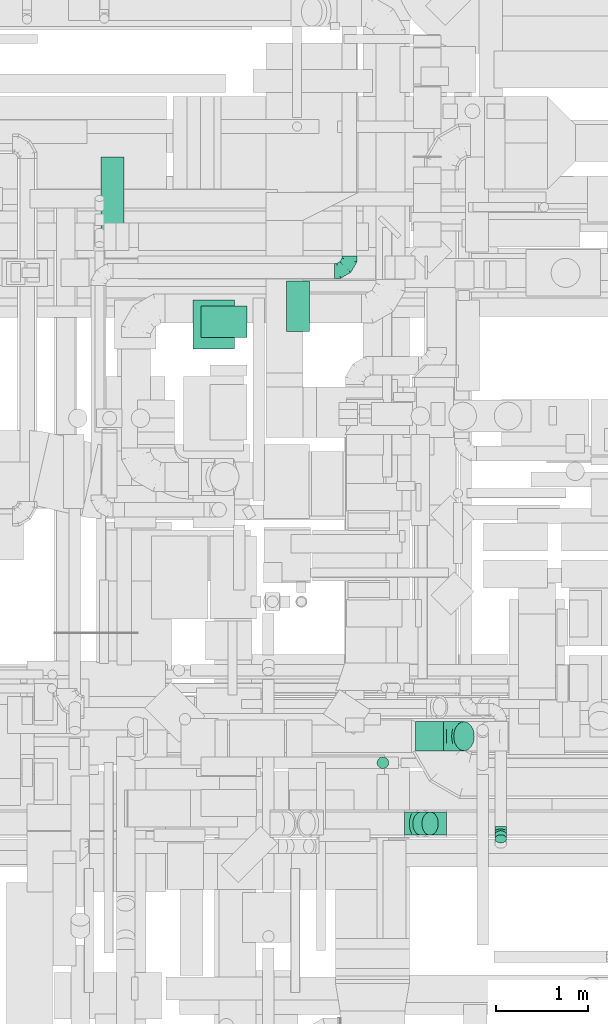
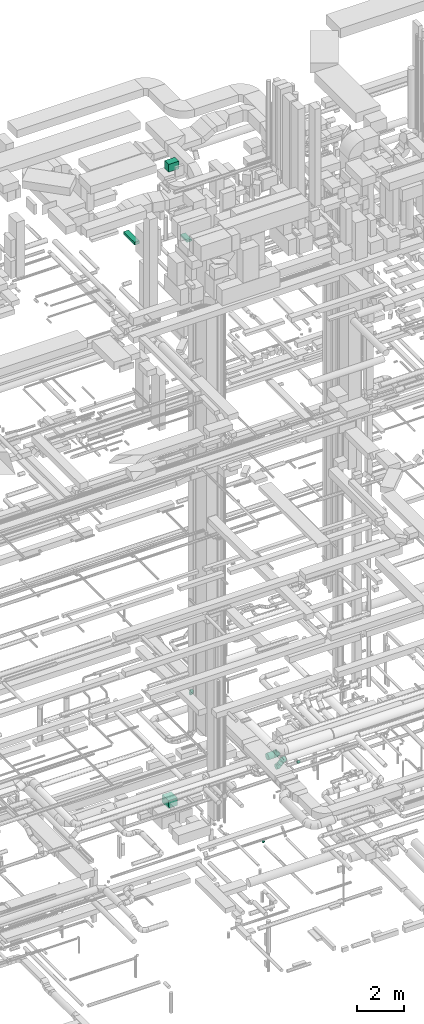
# One storey, part 178 of 337: 8 flow segments, 5 flow fittings.
"""IFC2X3 building model written with IfcOpenShell, lengths in millimetres."""

from ifc_helpers import new_model, entity, si_unit, converted_unit, derived_unit, direction, frame, origin, origin_2d_with_axis, place, context, subcontext, project, spatial, rectangle, circle, extrude, faceted_brep, source, transform, mapped, material, type_object, type_shapes, element, save


model = new_model("IFC2X3")

# Units and contexts
model_context = context("Model", 3, precision=0.01, world=origin(), true_north=direction((6.12303176911189e-17, 1.0)))
body_context = subcontext(model_context, "Body", "Model", "MODEL_VIEW")
ifc_project = project(units=[si_unit("LENGTHUNIT", "METRE", prefix="MILLI"), si_unit("AREAUNIT", "SQUARE_METRE"), si_unit("VOLUMEUNIT", "CUBIC_METRE"), converted_unit("PLANEANGLEUNIT", "DEGREE", entity("IfcRatioMeasure", 0.0174532925199433), si_unit("PLANEANGLEUNIT", "RADIAN"), dimensions=[0, 0, 0, 0, 0, 0, 0]), si_unit("MASSUNIT", "GRAM", prefix="KILO"), derived_unit("MASSDENSITYUNIT", [(si_unit("MASSUNIT", "GRAM", prefix="KILO"), 1), (si_unit("LENGTHUNIT", "METRE"), -3)]), derived_unit("MOMENTOFINERTIAUNIT", [(si_unit("LENGTHUNIT", "METRE"), 4)]), si_unit("TIMEUNIT", "SECOND"), si_unit("FREQUENCYUNIT", "HERTZ"), si_unit("THERMODYNAMICTEMPERATUREUNIT", "DEGREE_CELSIUS"), derived_unit("THERMALTRANSMITTANCEUNIT", [(si_unit("MASSUNIT", "GRAM", prefix="KILO"), 1), (si_unit("THERMODYNAMICTEMPERATUREUNIT", "KELVIN"), -1), (si_unit("TIMEUNIT", "SECOND"), -3)]), derived_unit("VOLUMETRICFLOWRATEUNIT", [(si_unit("LENGTHUNIT", "METRE"), 3), (si_unit("TIMEUNIT", "SECOND"), -1)]), derived_unit("MASSFLOWRATEUNIT", [(si_unit("MASSUNIT", "GRAM", prefix="KILO"), 1), (si_unit("TIMEUNIT", "SECOND"), -1)]), derived_unit("ROTATIONALFREQUENCYUNIT", [(si_unit("TIMEUNIT", "SECOND"), -1)]), si_unit("ELECTRICCURRENTUNIT", "AMPERE"), si_unit("ELECTRICVOLTAGEUNIT", "VOLT"), si_unit("POWERUNIT", "WATT"), si_unit("FORCEUNIT", "NEWTON", prefix="KILO"), si_unit("ILLUMINANCEUNIT", "LUX"), si_unit("LUMINOUSFLUXUNIT", "LUMEN"), si_unit("LUMINOUSINTENSITYUNIT", "CANDELA"), derived_unit("USERDEFINED", [(si_unit("MASSUNIT", "GRAM", prefix="KILO"), -1), (si_unit("LENGTHUNIT", "METRE"), -2), (si_unit("TIMEUNIT", "SECOND"), 3), (si_unit("LUMINOUSFLUXUNIT", "LUMEN"), 1)]), derived_unit("LINEARVELOCITYUNIT", [(si_unit("LENGTHUNIT", "METRE"), 1), (si_unit("TIMEUNIT", "SECOND"), -1)]), si_unit("PRESSUREUNIT", "PASCAL"), derived_unit("USERDEFINED", [(si_unit("LENGTHUNIT", "METRE"), -2), (si_unit("MASSUNIT", "GRAM", prefix="KILO"), 1), (si_unit("TIMEUNIT", "SECOND"), -2)]), derived_unit("LINEARFORCEUNIT", [(si_unit("MASSUNIT", "GRAM", prefix="KILO"), 1), (si_unit("LENGTHUNIT", "METRE"), 1), (si_unit("TIMEUNIT", "SECOND"), -2), (si_unit("LENGTHUNIT", "METRE"), -1)]), derived_unit("PLANARFORCEUNIT", [(si_unit("MASSUNIT", "GRAM", prefix="KILO"), 1), (si_unit("LENGTHUNIT", "METRE"), 1), (si_unit("TIMEUNIT", "SECOND"), -2), (si_unit("LENGTHUNIT", "METRE"), -2)])], contexts=[model_context])

# Site, building, storey
site_placement = place(None, origin())
site = spatial("IfcSite", under=ifc_project, at=site_placement, CompositionType="ELEMENT")
building_placement = place(site_placement, origin())
building = spatial("IfcBuilding", under=site, at=building_placement, CompositionType="ELEMENT")
storey_placement = place(building_placement, origin())
storey = spatial("IfcBuildingStorey", under=building, at=storey_placement, CompositionType="ELEMENT", Elevation=0.0)

# Flow segments
duct_segment_type_1 = type_object("IfcDuctSegmentType", PredefinedType="NOTDEFINED")
flow_segment_1_placement = place(storey_placement, frame((44232.27, 13725.33, -1300.0)))
element("IfcFlowSegment", 1, at=flow_segment_1_placement, inside=storey, type_object=duct_segment_type_1, context=body_context, shape_type="SweptSolid", body=[
    extrude(rectangle(XDim=528.06163199991, YDim=450.000000000002, at=origin_2d_with_axis()), frame((225.0, 264.03, 0.0), z_axis=(0.0, 0.0, 1.0), x_axis=(0.0, 1.0, 0.0)), (0.0, 0.0, 1.0), 400.0),
])
flow_segment_2_placement = place(storey_placement, frame((43238.94, 14881.21, 27475.0)))
element("IfcFlowSegment", 2, at=flow_segment_2_placement, inside=storey, type_object=duct_segment_type_1, context=body_context, shape_type="SweptSolid", body=[
    extrude(rectangle(XDim=919.338745030391, YDim=250.000000000004, at=origin_2d_with_axis()), frame((125.0, 459.67, 0.0), z_axis=(0.0, 0.0, 1.0), x_axis=(0.0, 1.0, 0.0)), (0.0, 0.0, 1.0), 150.000000000001),
])
flow_segment_3_placement = place(storey_placement, frame((45243.22, 13913.71, 27500.0)))
element("IfcFlowSegment", 3, at=flow_segment_3_placement, inside=storey, type_object=duct_segment_type_1, context=body_context, shape_type="SweptSolid", body=[
    extrude(rectangle(XDim=547.499999999984, YDim=250.000000000004, at=origin_2d_with_axis()), frame((125.0, 273.75, 0.0), z_axis=(0.0, 0.0, 1.0), x_axis=(0.0, -1.0, 0.0)), (0.0, 0.0, 1.0), 100.000000000003),
])
flow_segment_4_placement = place(storey_placement, frame((44320.31, 13849.12, 31500.0)))
element("IfcFlowSegment", 4, at=flow_segment_4_placement, inside=storey, type_object=duct_segment_type_1, context=body_context, shape_type="SweptSolid", body=[
    extrude(rectangle(XDim=340.000000000118, YDim=499.999999999999, at=origin_2d_with_axis()), frame((250.0, 170.0, 0.0), z_axis=(0.0, 0.0, 1.0), x_axis=(0.0, -1.0, 0.0)), (0.0, 0.0, 1.0), 399.999999999996),
])
duct_segment_type_2 = type_object("IfcDuctSegmentType", PredefinedType="NOTDEFINED")
flow_segment_5_placement = place(storey_placement, frame((46225.29, 9180.91, -1035.0)))
element("IfcFlowSegment", 5, at=flow_segment_5_placement, inside=storey, type_object=duct_segment_type_2, context=body_context, shape_type="SweptSolid", body=[
    extrude(circle(Radius=62.5, at=origin_2d_with_axis()), frame((64.1, 64.1, 0.0), z_axis=(0.0, 1.27955975282367e-05, 1.0), x_axis=(0.0, -1.0, 1.27955975282367e-05)), (0.0, 0.0, 1.0), 52.503404808983),
])
flow_segment_6_placement = place(storey_placement, frame((46611.51, 8460.07, 3163.24)))
element("IfcFlowSegment", 6, at=flow_segment_6_placement, inside=storey, type_object=duct_segment_type_2, context=body_context, shape_type="SweptSolid", body=[
    extrude(circle(Radius=125.0, at=origin_2d_with_axis()), frame((89.98, 126.6, 89.98), z_axis=(0.707106781186548, 0.0, 0.707106781186548), x_axis=(0.0, -1.0, 0.0)), (0.0, 0.0, 1.0), 139.375541594848),
])
flow_segment_7_placement = place(storey_placement, frame((47500.5, 8376.54, 3090.82)))
element("IfcFlowSegment", 7, at=flow_segment_7_placement, inside=storey, type_object=duct_segment_type_2, context=body_context, shape_type="SweptSolid", body=[
    extrude(circle(Radius=62.5, at=origin_2d_with_axis()), frame((64.1, 45.79, 89.36), z_axis=(0.0, 0.707106781186485, -0.70710678118661), x_axis=(-1.0, 0.0, 0.0)), (0.0, 0.0, 1.0), 61.6152603191933),
])
flow_segment_8_placement = place(storey_placement, frame((46641.56, 9373.4, 2920.9)))
element("IfcFlowSegment", 8, at=flow_segment_8_placement, inside=storey, type_object=duct_segment_type_2, context=body_context, shape_type="SweptSolid", body=[
    extrude(circle(Radius=157.5, at=origin_2d_with_axis()), frame((0.0, 159.1, 159.1), z_axis=(1.0, 0.0, 0.0), x_axis=(0.0, -1.0, 0.0)), (0.0, 0.0, 1.0), 302.74255936727),
])

# Flow fittings
ifc_material = material()
duct_fitting_type_1 = type_object("IfcDuctFittingType", PredefinedType="NOTDEFINED", material=ifc_material)
shared_shape_1 = source(origin(), body_context, "Body", "Brep", [
    faceted_brep([(-160.0, 0.0, -80.0), (-160.0, -20.71, -77.27), (-160.0, -40.0, -69.28), (-160.0, -56.57, -56.57), (-160.0, -69.28, -40.0), (-160.0, -77.27, -20.71), (-160.0, -80.0, 0.0), (-160.0, -77.27, 20.71), (-160.0, -69.28, 40.0), (-160.0, -56.57, 56.57), (-160.0, -40.0, 69.28), (-160.0, -20.71, 77.27), (-160.0, 0.0, 80.0), (-160.0, 20.71, 77.27), (-160.0, 40.0, 69.28), (-160.0, 56.57, 56.57), (-160.0, 69.28, 40.0), (-160.0, 77.27, 20.71), (-160.0, 80.0, 0.0), (-160.0, 77.27, -20.71), (-160.0, 69.28, -40.0), (-160.0, 56.57, -56.57), (-160.0, 40.0, -69.28), (-160.0, 20.71, -77.27), (-122.68, 20.71, 77.27), (-127.85, 40.0, 69.28), (-117.13, 0.0, 80.0), (-132.29, 56.57, 56.57), (-137.83, 77.27, 20.71), (-138.56, 80.0, 0.0), (-135.69, 69.28, 40.0), (-135.69, 69.28, -40.0), (-132.29, 56.57, -56.57), (-137.83, 77.27, -20.71), (-122.68, 20.71, -77.27), (-117.13, 0.0, -80.0), (-127.85, 40.0, -69.28), (-111.58, -20.71, -77.27), (-106.41, -40.0, -69.28), (-101.97, -56.57, -56.57), (-98.56, -69.28, -40.0), (-96.42, -77.27, -20.71), (-95.69, -80.0, 0.0), (-96.42, -77.27, 20.71), (-98.56, -69.28, 40.0), (-101.97, -56.57, 56.57), (-106.41, -40.0, 69.28), (-111.58, -20.71, 77.27), (-58.03, 58.03, 77.27), (-72.15, 72.15, 69.28), (-42.87, 42.87, 80.0), (-84.28, 84.28, 56.57), (-93.59, 93.59, 40.0), (-99.44, 99.44, 20.71), (-101.44, 101.44, 0.0), (-99.44, 99.44, -20.71), (-93.59, 93.59, -40.0), (-84.28, 84.28, -56.57), (-58.03, 58.03, -77.27), (-42.87, 42.87, -80.0), (-72.15, 72.15, -69.28), (-27.71, 27.71, -77.27), (-13.59, 13.59, -69.28), (-1.46, 1.46, -56.57), (7.85, -7.85, -40.0), (13.7, -13.7, -20.71), (15.69, -15.69, 0.0), (13.7, -13.7, 20.71), (7.85, -7.85, 40.0), (-1.46, 1.46, 56.57), (-13.59, 13.59, 69.28), (-27.71, 27.71, 77.27), (-20.71, 122.68, 77.27), (-40.0, 127.85, 69.28), (0.0, 117.13, 80.0), (-56.57, 132.29, 56.57), (-69.28, 135.69, 40.0), (-77.27, 137.83, 20.71), (-80.0, 138.56, 0.0), (-77.27, 137.83, -20.71), (-69.28, 135.69, -40.0), (-56.57, 132.29, -56.57), (-20.71, 122.68, -77.27), (0.0, 117.13, -80.0), (-40.0, 127.85, -69.28), (20.71, 111.58, -77.27), (40.0, 106.41, -69.28), (56.57, 101.97, -56.57), (69.28, 98.56, -40.0), (77.27, 96.42, -20.71), (80.0, 95.69, 0.0), (77.27, 96.42, 20.71), (69.28, 98.56, 40.0), (56.57, 101.97, 56.57), (40.0, 106.41, 69.28), (20.71, 111.58, 77.27), (-20.71, 160.0, -77.27), (-40.0, 160.0, -69.28), (-56.57, 160.0, -56.57), (-69.28, 160.0, -40.0), (-77.27, 160.0, -20.71), (-80.0, 160.0, 0.0), (-77.27, 160.0, 20.71), (-69.28, 160.0, 40.0), (-56.57, 160.0, 56.57), (-40.0, 160.0, 69.28), (-20.71, 160.0, 77.27), (0.0, 160.0, 80.0), (20.71, 160.0, 77.27), (40.0, 160.0, 69.28), (56.57, 160.0, 56.57), (69.28, 160.0, 40.0), (77.27, 160.0, 20.71), (80.0, 160.0, 0.0), (77.27, 160.0, -20.71), (69.28, 160.0, -40.0), (56.57, 160.0, -56.57), (40.0, 160.0, -69.28), (20.71, 160.0, -77.27), (0.0, 160.0, -80.0)], [[[0, 1, 2, 3, 4, 5, 6, 7, 8, 9, 10, 11, 12, 13, 14, 15, 16, 17, 18, 19, 20, 21, 22, 23]], [[24, 25, 14, 13]], [[26, 24, 13, 12]], [[14, 25, 27, 15]], [[28, 29, 18, 17]], [[30, 28, 17, 16]], [[15, 27, 30, 16]], [[20, 31, 32, 21]], [[33, 31, 20, 19]], [[18, 29, 33, 19]], [[34, 35, 0, 23]], [[36, 34, 23, 22]], [[32, 36, 22, 21]], [[1, 0, 35, 37]], [[2, 1, 37, 38]], [[3, 2, 38, 39]], [[5, 4, 40, 41]], [[6, 5, 41, 42]], [[39, 40, 4, 3]], [[6, 42, 43, 7]], [[7, 43, 44, 8]], [[8, 44, 45, 9]], [[9, 45, 46, 10]], [[10, 46, 47, 11]], [[26, 12, 11, 47]], [[48, 49, 25, 24]], [[50, 48, 24, 26]], [[27, 25, 49, 51]], [[52, 53, 28, 30]], [[51, 52, 30, 27]], [[29, 28, 53, 54]], [[55, 56, 31, 33]], [[54, 55, 33, 29]], [[32, 31, 56, 57]], [[58, 59, 35, 34]], [[60, 58, 34, 36]], [[57, 60, 36, 32]], [[37, 35, 59, 61]], [[38, 37, 61, 62]], [[39, 38, 62, 63]], [[41, 40, 64, 65]], [[42, 41, 65, 66]], [[63, 64, 40, 39]], [[43, 42, 66, 67]], [[44, 43, 67, 68]], [[68, 69, 45, 44]], [[46, 45, 69, 70]], [[47, 46, 70, 71]], [[26, 47, 71, 50]], [[72, 73, 49, 48]], [[74, 72, 48, 50]], [[51, 49, 73, 75]], [[76, 77, 53, 52]], [[75, 76, 52, 51]], [[54, 53, 77, 78]], [[79, 80, 56, 55]], [[78, 79, 55, 54]], [[57, 56, 80, 81]], [[82, 83, 59, 58]], [[84, 82, 58, 60]], [[81, 84, 60, 57]], [[61, 59, 83, 85]], [[62, 61, 85, 86]], [[63, 62, 86, 87]], [[65, 64, 88, 89]], [[66, 65, 89, 90]], [[87, 88, 64, 63]], [[67, 66, 90, 91]], [[68, 67, 91, 92]], [[92, 93, 69, 68]], [[70, 69, 93, 94]], [[71, 70, 94, 95]], [[50, 71, 95, 74]], [[96, 97, 98, 99, 100, 101, 102, 103, 104, 105, 106, 107, 108, 109, 110, 111, 112, 113, 114, 115, 116, 117, 118, 119]], [[72, 74, 107, 106]], [[73, 72, 106, 105]], [[75, 73, 105, 104]], [[77, 76, 103, 102]], [[78, 77, 102, 101]], [[75, 104, 103, 76]], [[78, 101, 100, 79]], [[79, 100, 99, 80]], [[80, 99, 98, 81]], [[84, 97, 96, 82]], [[82, 96, 119, 83]], [[84, 81, 98, 97]], [[118, 117, 86, 85]], [[119, 118, 85, 83]], [[116, 87, 86, 117]], [[88, 115, 114, 89]], [[89, 114, 113, 90]], [[115, 88, 87, 116]], [[112, 111, 92, 91]], [[113, 112, 91, 90]], [[111, 110, 93, 92]], [[95, 94, 109, 108]], [[74, 95, 108, 107]], [[110, 109, 94, 93]]]),
])
type_shapes(duct_fitting_type_1, [shared_shape_1])
flow_fitting_1_placement = place(storey_placement, frame((45926.64, 14568.87, 3600.0)))
element("IfcFlowFitting", 9, at=flow_fitting_1_placement, inside=storey, type_object=duct_fitting_type_1, material=ifc_material, context=body_context, shape_type="MappedRepresentation", body=[
    mapped(shared_shape_1, transform((0.0, 0.0, 0.0), scale=1.0)),
])
duct_fitting_type_2 = type_object("IfcDuctFittingType", PredefinedType="NOTDEFINED", material=ifc_material)
shared_shape_2 = source(origin(), body_context, "Body", "Brep", [
    faceted_brep([(-51.78, 0.0, -62.5), (-51.78, -16.18, -60.37), (-51.78, -31.25, -54.13), (-51.78, -44.19, -44.19), (-51.78, -54.13, -31.25), (-51.78, -60.37, -16.18), (-51.78, -62.5, 0.0), (-51.78, -60.37, 16.18), (-51.78, -54.13, 31.25), (-51.78, -44.19, 44.19), (-51.78, -31.25, 54.13), (-51.78, -16.18, 60.37), (-51.78, 0.0, 62.5), (-51.78, 16.18, 60.37), (-51.78, 31.25, 54.13), (-51.78, 44.19, 44.19), (-51.78, 54.13, 31.25), (-51.78, 60.37, 16.18), (-51.78, 62.5, 0.0), (-51.78, 60.37, -16.18), (-51.78, 54.13, -31.25), (-51.78, 44.19, -44.19), (-51.78, 31.25, -54.13), (-51.78, 16.18, -60.37), (-6.7, 16.18, 60.37), (-12.94, 31.25, 54.13), (0.0, 0.0, 62.5), (-18.31, 44.19, 44.19), (-22.42, 54.13, 31.25), (-25.01, 60.37, 16.18), (-25.89, 62.5, 0.0), (-25.01, 60.37, -16.18), (-22.42, 54.13, -31.25), (-18.31, 44.19, -44.19), (-6.7, 16.18, -60.37), (0.0, 0.0, -62.5), (-12.94, 31.25, -54.13), (6.7, -16.18, -60.37), (12.94, -31.25, -54.13), (18.31, -44.19, -44.19), (22.42, -54.13, -31.25), (25.01, -60.37, -16.18), (25.89, -62.5, 0.0), (25.01, -60.37, 16.18), (22.42, -54.13, 31.25), (18.31, -44.19, 44.19), (12.94, -31.25, 54.13), (6.7, -16.18, 60.37), (25.17, 48.05, 60.37), (14.51, 58.71, 54.13), (36.61, 36.61, 62.5), (5.36, 67.86, 44.19), (-1.66, 74.88, 31.25), (-6.08, 79.3, 16.18), (-7.58, 80.81, 0.0), (-6.08, 79.3, -16.18), (-1.66, 74.88, -31.25), (5.36, 67.86, -44.19), (14.51, 58.71, -54.13), (25.17, 48.05, -60.37), (36.61, 36.61, -62.5), (48.05, 25.17, -60.37), (58.71, 14.51, -54.13), (67.86, 5.36, -44.19), (74.88, -1.66, -31.25), (79.3, -6.08, -16.18), (80.81, -7.58, 0.0), (79.3, -6.08, 16.18), (74.88, -1.66, 31.25), (67.86, 5.36, 44.19), (58.71, 14.51, 54.13), (48.05, 25.17, 60.37)], [[[0, 1, 2, 3, 4, 5, 6, 7, 8, 9, 10, 11, 12, 13, 14, 15, 16, 17, 18, 19, 20, 21, 22, 23]], [[24, 25, 14, 13]], [[26, 24, 13, 12]], [[27, 15, 14, 25]], [[28, 29, 17, 16]], [[28, 16, 15, 27]], [[30, 18, 17, 29]], [[31, 32, 20, 19]], [[30, 31, 19, 18]], [[21, 20, 32, 33]], [[34, 35, 0, 23]], [[36, 34, 23, 22]], [[33, 36, 22, 21]], [[1, 0, 35, 37]], [[2, 1, 37, 38]], [[38, 39, 3, 2]], [[5, 4, 40, 41]], [[6, 5, 41, 42]], [[39, 40, 4, 3]], [[6, 42, 43, 7]], [[7, 43, 44, 8]], [[8, 44, 45, 9]], [[9, 45, 46, 10]], [[10, 46, 47, 11]], [[26, 12, 11, 47]], [[48, 49, 25, 24]], [[50, 48, 24, 26]], [[27, 25, 49, 51]], [[29, 28, 52, 53]], [[30, 29, 53, 54]], [[51, 52, 28, 27]], [[30, 54, 55, 31]], [[31, 55, 56, 32]], [[57, 33, 32, 56]], [[36, 58, 59, 34]], [[34, 59, 60, 35]], [[58, 36, 33, 57]], [[35, 60, 61, 37]], [[37, 61, 62, 38]], [[63, 39, 38, 62]], [[40, 64, 65, 41]], [[41, 65, 66, 42]], [[64, 40, 39, 63]], [[43, 42, 66, 67]], [[44, 43, 67, 68]], [[68, 69, 45, 44]], [[47, 46, 70, 71]], [[26, 47, 71, 50]], [[69, 70, 46, 45]], [[59, 58, 57, 56, 55, 54, 53, 52, 51, 49, 48, 50, 71, 70, 69, 68, 67, 66, 65, 64, 63, 62, 61, 60]]]),
])
type_shapes(duct_fitting_type_2, [shared_shape_2])
flow_fitting_2_placement = place(storey_placement, frame((47564.59, 8502.51, 3100.0), z_axis=(-1.0, 0.0, 0.0), x_axis=(0.0, -1.0, 0.0)))
element("IfcFlowFitting", 10, at=flow_fitting_2_placement, inside=storey, type_object=duct_fitting_type_2, material=ifc_material, context=body_context, shape_type="MappedRepresentation", body=[
    mapped(shared_shape_2, transform((0.0, 0.0, 0.0), scale=1.0)),
])
duct_fitting_type_3 = type_object("IfcDuctFittingType", PredefinedType="NOTDEFINED", material=ifc_material)
shared_shape_3 = source(origin(), body_context, "Body", "Brep", [
    faceted_brep([(-103.55, 0.0, -125.0), (-103.55, -32.35, -120.74), (-103.55, -62.5, -108.25), (-103.55, -88.39, -88.39), (-103.55, -108.25, -62.5), (-103.55, -120.74, -32.35), (-103.55, -125.0, 0.0), (-103.55, -120.74, 32.35), (-103.55, -108.25, 62.5), (-103.55, -88.39, 88.39), (-103.55, -62.5, 108.25), (-103.55, -32.35, 120.74), (-103.55, 0.0, 125.0), (-103.55, 32.35, 120.74), (-103.55, 62.5, 108.25), (-103.55, 88.39, 88.39), (-103.55, 108.25, 62.5), (-103.55, 120.74, 32.35), (-103.55, 125.0, 0.0), (-103.55, 120.74, -32.35), (-103.55, 108.25, -62.5), (-103.55, 88.39, -88.39), (-103.55, 62.5, -108.25), (-103.55, 32.35, -120.74), (-13.4, 32.35, 120.74), (-25.89, 62.5, 108.25), (0.0, 0.0, 125.0), (-36.61, 88.39, 88.39), (-44.84, 108.25, 62.5), (-50.01, 120.74, 32.35), (-51.78, 125.0, 0.0), (-50.01, 120.74, -32.35), (-44.84, 108.25, -62.5), (-36.61, 88.39, -88.39), (-13.4, 32.35, -120.74), (0.0, 0.0, -125.0), (-25.89, 62.5, -108.25), (13.4, -32.35, -120.74), (25.89, -62.5, -108.25), (36.61, -88.39, -88.39), (44.84, -108.25, -62.5), (50.01, -120.74, -32.35), (51.78, -125.0, 0.0), (50.01, -120.74, 32.35), (44.84, -108.25, 62.5), (36.61, -88.39, 88.39), (25.89, -62.5, 108.25), (13.4, -32.35, 120.74), (73.22, 73.22, 125.0), (50.35, 96.1, 120.74), (29.03, 117.42, 108.25), (10.72, 135.72, 88.39), (-3.32, 149.77, 62.5), (-12.15, 158.6, 32.35), (-15.17, 161.61, 0.0), (-12.15, 158.6, -32.35), (-3.32, 149.77, -62.5), (10.72, 135.72, -88.39), (29.03, 117.42, -108.25), (50.35, 96.1, -120.74), (73.22, 73.22, -125.0), (96.1, 50.35, -120.74), (117.42, 29.03, -108.25), (135.72, 10.72, -88.39), (149.77, -3.32, -62.5), (158.6, -12.15, -32.35), (161.61, -15.17, 0.0), (158.6, -12.15, 32.35), (149.77, -3.32, 62.5), (135.72, 10.72, 88.39), (117.42, 29.03, 108.25), (96.1, 50.35, 120.74)], [[[0, 1, 2, 3, 4, 5, 6, 7, 8, 9, 10, 11, 12, 13, 14, 15, 16, 17, 18, 19, 20, 21, 22, 23]], [[24, 25, 14, 13]], [[26, 24, 13, 12]], [[14, 25, 27, 15]], [[28, 29, 17, 16]], [[28, 16, 15, 27]], [[30, 18, 17, 29]], [[31, 32, 20, 19]], [[30, 31, 19, 18]], [[32, 33, 21, 20]], [[34, 35, 0, 23]], [[36, 34, 23, 22]], [[33, 36, 22, 21]], [[1, 0, 35, 37]], [[2, 1, 37, 38]], [[38, 39, 3, 2]], [[5, 4, 40, 41]], [[6, 5, 41, 42]], [[39, 40, 4, 3]], [[6, 42, 43, 7]], [[7, 43, 44, 8]], [[8, 44, 45, 9]], [[9, 45, 46, 10]], [[10, 46, 47, 11]], [[26, 12, 11, 47]], [[24, 26, 48, 49]], [[25, 24, 49, 50]], [[27, 25, 50, 51]], [[29, 28, 52, 53]], [[30, 29, 53, 54]], [[51, 52, 28, 27]], [[30, 54, 55, 31]], [[31, 55, 56, 32]], [[57, 33, 32, 56]], [[36, 58, 59, 34]], [[34, 59, 60, 35]], [[58, 36, 33, 57]], [[35, 60, 61, 37]], [[37, 61, 62, 38]], [[63, 39, 38, 62]], [[40, 64, 65, 41]], [[41, 65, 66, 42]], [[64, 40, 39, 63]], [[43, 42, 66, 67]], [[44, 43, 67, 68]], [[68, 69, 45, 44]], [[47, 46, 70, 71]], [[26, 47, 71, 48]], [[69, 70, 46, 45]], [[59, 58, 57, 56, 55, 54, 53, 52, 51, 50, 49, 48, 71, 70, 69, 68, 67, 66, 65, 64, 63, 62, 61, 60]]]),
])
type_shapes(duct_fitting_type_3, [shared_shape_3])
for number, where, z_axis, x_axis in (
    (11, (46628.27, 8586.67, 3180.0), (0.0, -1.0, 0.0), (1.0, 0.0, 0.0)),
    (12, (46873.27, 8586.67, 3425.0), (0.0, 1.0, 0.0), (0.707106781186499, 0.0, 0.707106781186596)),
):
    element("IfcFlowFitting", number, at=place(storey_placement, frame(where, z_axis=z_axis, x_axis=x_axis)), inside=storey, type_object=duct_fitting_type_3, material=ifc_material, context=body_context, shape_type="MappedRepresentation", body=[
        mapped(shared_shape_3, transform((0.0, 0.0, 0.0), scale=1.0)),
    ])
duct_fitting_type_4 = type_object("IfcDuctFittingType", PredefinedType="NOTDEFINED", material=ifc_material)
shared_shape_4 = source(origin(), body_context, "Body", "Brep", [
    faceted_brep([(-130.48, 0.0, -157.5), (-130.48, -40.76, -152.13), (-130.48, -78.75, -136.4), (-130.48, -111.37, -111.37), (-130.48, -136.4, -78.75), (-130.48, -152.13, -40.76), (-130.48, -157.5, 0.0), (-130.48, -152.13, 40.76), (-130.48, -136.4, 78.75), (-130.48, -111.37, 111.37), (-130.48, -78.75, 136.4), (-130.48, -40.76, 152.13), (-130.48, 0.0, 157.5), (-130.48, 40.76, 152.13), (-130.48, 78.75, 136.4), (-130.48, 111.37, 111.37), (-130.48, 136.4, 78.75), (-130.48, 152.13, 40.76), (-130.48, 157.5, 0.0), (-130.48, 152.13, -40.76), (-130.48, 136.4, -78.75), (-130.48, 111.37, -111.37), (-130.48, 78.75, -136.4), (-130.48, 40.76, -152.13), (-75.93, 40.76, 152.13), (-83.48, 78.75, 136.4), (-67.82, 0.0, 157.5), (-89.97, 111.37, 111.37), (-94.95, 136.4, 78.75), (-98.08, 152.13, 40.76), (-99.15, 157.5, 0.0), (-98.08, 152.13, -40.76), (-94.95, 136.4, -78.75), (-89.97, 111.37, -111.37), (-75.93, 40.76, -152.13), (-67.82, 0.0, -157.5), (-83.48, 78.75, -136.4), (-59.71, -40.76, -152.13), (-52.16, -78.75, -136.4), (-45.67, -111.37, -111.37), (-40.69, -136.4, -78.75), (-37.56, -152.13, -40.76), (-36.49, -157.5, 0.0), (-37.56, -152.13, 40.76), (-40.69, -136.4, 78.75), (-45.67, -111.37, 111.37), (-52.16, -78.75, 136.4), (-59.71, -40.76, 152.13), (24.86, 82.51, 152.13), (3.35, 114.72, 136.4), (47.96, 47.96, 157.5), (-15.13, 142.37, 111.37), (-29.31, 163.59, 78.75), (-38.22, 176.93, 40.76), (-41.26, 181.48, 0.0), (-38.22, 176.93, -40.76), (-29.31, 163.59, -78.75), (-15.13, 142.37, -111.37), (24.86, 82.51, -152.13), (47.96, 47.96, -157.5), (3.35, 114.72, -136.4), (71.05, 13.4, -152.13), (92.56, -18.81, -136.4), (111.04, -46.46, -111.37), (125.22, -67.68, -78.75), (134.13, -81.02, -40.76), (137.17, -85.57, 0.0), (134.13, -81.02, 40.76), (125.22, -67.68, 78.75), (111.04, -46.46, 111.37), (92.56, -18.81, 136.4), (71.05, 13.4, 152.13), (92.26, 92.26, 157.5), (63.44, 121.09, 152.13), (36.58, 147.95, 136.4), (13.51, 171.01, 111.37), (-4.19, 188.71, 78.75), (-15.31, 199.84, 40.76), (-19.11, 203.63, 0.0), (-15.31, 199.84, -40.76), (-4.19, 188.71, -78.75), (13.51, 171.01, -111.37), (36.58, 147.95, -136.4), (63.44, 121.09, -152.13), (92.26, 92.26, -157.5), (121.09, 63.44, -152.13), (147.95, 36.58, -136.4), (171.01, 13.51, -111.37), (188.71, -4.19, -78.75), (199.84, -15.31, -40.76), (203.63, -19.11, 0.0), (199.84, -15.31, 40.76), (188.71, -4.19, 78.75), (171.01, 13.51, 111.37), (147.95, 36.58, 136.4), (121.09, 63.44, 152.13)], [[[0, 1, 2, 3, 4, 5, 6, 7, 8, 9, 10, 11, 12, 13, 14, 15, 16, 17, 18, 19, 20, 21, 22, 23]], [[24, 25, 14, 13]], [[26, 24, 13, 12]], [[27, 15, 14, 25]], [[28, 29, 17, 16]], [[28, 16, 15, 27]], [[30, 18, 17, 29]], [[31, 32, 20, 19]], [[30, 31, 19, 18]], [[21, 20, 32, 33]], [[34, 35, 0, 23]], [[36, 34, 23, 22]], [[33, 36, 22, 21]], [[1, 0, 35, 37]], [[2, 1, 37, 38]], [[3, 2, 38, 39]], [[5, 4, 40, 41]], [[6, 5, 41, 42]], [[39, 40, 4, 3]], [[6, 42, 43, 7]], [[7, 43, 44, 8]], [[45, 9, 8, 44]], [[9, 45, 46, 10]], [[10, 46, 47, 11]], [[26, 12, 11, 47]], [[48, 49, 25, 24]], [[50, 48, 24, 26]], [[27, 25, 49, 51]], [[52, 53, 29, 28]], [[51, 52, 28, 27]], [[30, 29, 53, 54]], [[55, 56, 32, 31]], [[54, 55, 31, 30]], [[33, 32, 56, 57]], [[58, 59, 35, 34]], [[60, 58, 34, 36]], [[57, 60, 36, 33]], [[37, 35, 59, 61]], [[38, 37, 61, 62]], [[39, 38, 62, 63]], [[41, 40, 64, 65]], [[42, 41, 65, 66]], [[63, 64, 40, 39]], [[43, 42, 66, 67]], [[44, 43, 67, 68]], [[68, 69, 45, 44]], [[46, 45, 69, 70]], [[47, 46, 70, 71]], [[26, 47, 71, 50]], [[48, 50, 72, 73]], [[49, 48, 73, 74]], [[51, 49, 74, 75]], [[53, 52, 76, 77]], [[54, 53, 77, 78]], [[51, 75, 76, 52]], [[54, 78, 79, 55]], [[55, 79, 80, 56]], [[56, 80, 81, 57]], [[60, 82, 83, 58]], [[58, 83, 84, 59]], [[60, 57, 81, 82]], [[85, 86, 62, 61]], [[84, 85, 61, 59]], [[87, 63, 62, 86]], [[64, 88, 89, 65]], [[65, 89, 90, 66]], [[88, 64, 63, 87]], [[91, 92, 68, 67]], [[90, 91, 67, 66]], [[92, 93, 69, 68]], [[71, 70, 94, 95]], [[50, 71, 95, 72]], [[93, 94, 70, 69]], [[83, 82, 81, 80, 79, 78, 77, 76, 75, 74, 73, 72, 95, 94, 93, 92, 91, 90, 89, 88, 87, 86, 85, 84]]]),
])
type_shapes(duct_fitting_type_4, [shared_shape_4])
flow_fitting_3_placement = place(storey_placement, frame((47074.78, 9532.5, 3080.0), z_axis=(0.0, -1.0, 0.0), x_axis=(1.0, 0.0, 0.0)))
element("IfcFlowFitting", 13, at=flow_fitting_3_placement, inside=storey, type_object=duct_fitting_type_4, material=ifc_material, context=body_context, shape_type="MappedRepresentation", body=[
    mapped(shared_shape_4, transform((0.0, 0.0, 0.0), scale=1.0)),
])

save(model, "model.ifc")
